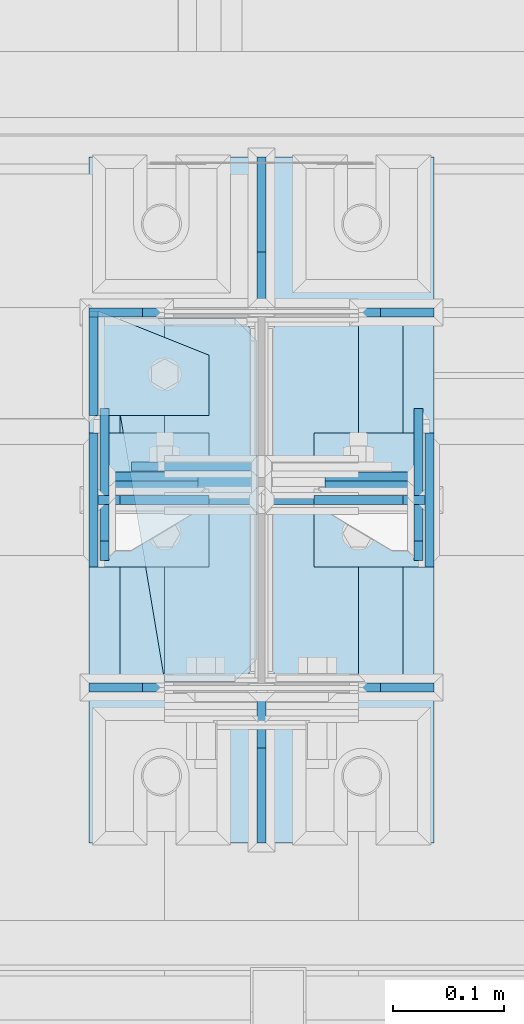
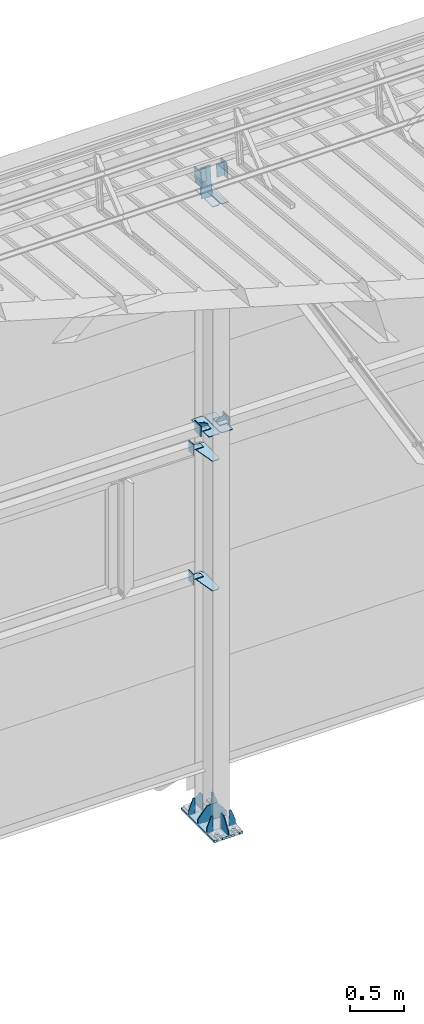
# One storey, part 160 of 709: 30 plates, 4 openings, 7 elements without a shape of their own.
"""IFC4 building model written with IfcOpenShell, lengths in millimetres."""

from ifc_helpers import new_model, si_unit, direction, frame, origin_with_axes, place, context, subcontext, project, spatial, line, arc, indexed_curve, outline, extrude, material, element, aggregate, save


model = new_model("IFC4")

# Units and contexts
model_context = context("Model", 3, precision=0.2, world=origin_with_axes(), true_north=direction((0.0, 1.0)))
body_context = subcontext(model_context, "Body", "Model", "MODEL_VIEW")
ifc_project = project(units=[si_unit("LENGTHUNIT", "METRE", prefix="MILLI"), si_unit("AREAUNIT", "SQUARE_METRE"), si_unit("VOLUMEUNIT", "CUBIC_METRE"), si_unit("MASSUNIT", "GRAM", prefix="KILO"), si_unit("TIMEUNIT", "SECOND"), si_unit("PLANEANGLEUNIT", "RADIAN"), si_unit("SOLIDANGLEUNIT", "STERADIAN"), si_unit("THERMODYNAMICTEMPERATUREUNIT", "DEGREE_CELSIUS"), si_unit("LUMINOUSINTENSITYUNIT", "LUMEN")], contexts=[model_context])

# Site, building, storey
site_placement = place(None, origin_with_axes())
site = spatial("IfcSite", under=ifc_project, at=site_placement, CompositionType="ELEMENT")
building_placement = place(site_placement, origin_with_axes())
building = spatial("IfcBuilding", under=site, at=building_placement, Name="Undefined", CompositionType="ELEMENT")
storey_placement = place(building_placement, origin_with_axes())
storey = spatial("IfcBuildingStorey", under=building, at=storey_placement, Name="Undefined", CompositionType="ELEMENT", Elevation=0.0)

# Assembly, plates, voiding features
assembly_1_placement = place(storey_placement, frame((34000.0, 21827.0, -200.0), z_axis=(-1.0, 0.0, 0.0), x_axis=(0.0, 0.0, 1.0)))
assembly_1 = element("IfcElementAssembly", 1, at=assembly_1_placement, inside=storey)
ifc_material = material(Name="C355-6", Category="STEEL")
plate_1_placement = place(assembly_1_placement, frame((12.5, -308.0, 155.0), z_axis=(1.0, 0.0, 0.0), x_axis=(0.0, 0.0, -1.0)))
plate_1 = element("IfcPlate", 2, at=plate_1_placement, material=ifc_material, ObjectType="416", context=body_context, shape_type="SolidModel", body=[
    extrude(outline(indexed_curve([(0.0, 0.0), (310.0, 0.0), (310.0, 616.0), (0.0, 616.0)], segments=[line(1, 2, 3, 4, 1)])), frame((0.0, 0.0, 12.5), z_axis=(0.0, 0.0, 1.0), x_axis=(1.0, 0.0, 0.0)), (0.0, 0.0, -1.0), 25.0),
])
voiding_feature_1_placement = place(plate_1_placement, frame((40.0, 616.0, 0.0), z_axis=(0.0, 0.0, -1.0), x_axis=(1.0, 0.0, 0.0)))
element("IfcVoidingFeature", 3, at=voiding_feature_1_placement, cuts=plate_1, PredefinedType="HOLE", context=body_context, shape_type="SolidModel", body=[
    extrude(outline(indexed_curve([(0.0, 0.0), (50.0, 0.0), (50.0, 60.0), (42.67767, 77.67767), (25.0, 85.0), (25.0, 85.0), (7.32233, 77.67767), (0.0, 60.0)], segments=[line(1, 2, 3), arc(3, 4, 5), line(5, 6), arc(6, 7, 8), line(8, 1)])), frame((0.0, 0.0, 12.5), z_axis=(0.0, 0.0, 1.0), x_axis=(1.0, 0.0, 0.0)), (0.0, 0.0, -1.0), 25.0),
])
voiding_feature_2_placement = place(plate_1_placement, frame((40.0, 0.0, 0.0), z_axis=(0.0, 0.0, 1.0), x_axis=(1.0, 0.0, 0.0)))
element("IfcVoidingFeature", 4, at=voiding_feature_2_placement, cuts=plate_1, PredefinedType="HOLE", context=body_context, shape_type="SolidModel", body=[
    extrude(outline(indexed_curve([(0.0, 0.0), (50.0, 0.0), (50.0, 60.0), (42.67767, 77.67767), (25.0, 85.0), (25.0, 85.0), (7.32233, 77.67767), (0.0, 60.0)], segments=[line(1, 2, 3), arc(3, 4, 5), line(5, 6), arc(6, 7, 8), line(8, 1)])), frame((0.0, 0.0, 12.5), z_axis=(0.0, 0.0, 1.0), x_axis=(1.0, 0.0, 0.0)), (0.0, 0.0, -1.0), 25.0),
])
voiding_feature_3_placement = place(plate_1_placement, frame((270.0, 616.0, 0.0), z_axis=(0.0, 0.0, 1.0), x_axis=(-1.0, 0.0, 0.0)))
element("IfcVoidingFeature", 5, at=voiding_feature_3_placement, cuts=plate_1, PredefinedType="HOLE", context=body_context, shape_type="SolidModel", body=[
    extrude(outline(indexed_curve([(0.0, 0.0), (50.0, 0.0), (50.0, 60.0), (42.67767, 77.67767), (25.0, 85.0), (25.0, 85.0), (7.32233, 77.67767), (0.0, 60.0)], segments=[line(1, 2, 3), arc(3, 4, 5), line(5, 6), arc(6, 7, 8), line(8, 1)])), frame((0.0, 0.0, 12.5), z_axis=(0.0, 0.0, 1.0), x_axis=(1.0, 0.0, 0.0)), (0.0, 0.0, -1.0), 25.0),
])
voiding_feature_4_placement = place(plate_1_placement, frame((270.0, 0.0, 0.0), z_axis=(0.0, 0.0, -1.0), x_axis=(-1.0, 0.0, 0.0)))
element("IfcVoidingFeature", 6, at=voiding_feature_4_placement, cuts=plate_1, PredefinedType="HOLE", context=body_context, shape_type="SolidModel", body=[
    extrude(outline(indexed_curve([(0.0, 0.0), (50.0, 0.0), (50.0, 60.0), (42.67767, 77.67767), (25.0, 85.0), (25.0, 85.0), (7.32233, 77.67767), (0.0, 60.0)], segments=[line(1, 2, 3), arc(3, 4, 5), line(5, 6), arc(6, 7, 8), line(8, 1)])), frame((0.0, 0.0, 12.5), z_axis=(0.0, 0.0, 1.0), x_axis=(1.0, 0.0, 0.0)), (0.0, 0.0, -1.0), 25.0),
])
plate_2_placement = place(assembly_1_placement, frame((25.0, 0.0, -3.0), z_axis=(0.0, -1.0, 0.0), x_axis=(0.0, 0.0, -1.0)))
plate_2 = element("IfcPlate", 7, at=plate_2_placement, material=ifc_material, ObjectType="417", context=body_context, shape_type="SolidModel", body=[
    extrude(outline(indexed_curve([(0.0, 0.0), (152.0, 0.0), (152.0, 50.0), (50.0, 175.0), (0.0, 175.0)], segments=[line(1, 2, 3, 4, 5, 1)])), frame((0.0, 0.0, 4.0), z_axis=(0.0, 0.0, 1.0), x_axis=(1.0, 0.0, 0.0)), (0.0, 0.0, -1.0), 8.0),
])
plate_3_placement = place(assembly_1_placement, frame((25.0, -168.5, 87.0), z_axis=(0.0, 1.0, 0.0), x_axis=(0.0, 0.0, 1.0)))
plate_3 = element("IfcPlate", 8, at=plate_3_placement, material=ifc_material, ObjectType="419", context=body_context, shape_type="SolidModel", body=[
    extrude(outline(indexed_curve([(0.0, 0.0), (68.0, 0.0), (68.0, 50.0), (20.0, 175.0), (0.0, 175.0)], segments=[line(1, 2, 3, 4, 5, 1)])), frame((0.0, 0.0, 4.0), z_axis=(0.0, 0.0, 1.0), x_axis=(1.0, 0.0, 0.0)), (0.0, 0.0, -1.0), 8.0),
])
plate_4_placement = place(assembly_1_placement, frame((25.0, 0.0, 3.0), z_axis=(0.0, 1.0, 0.0), x_axis=(0.0, 0.0, 1.0)))
plate_4 = element("IfcPlate", 9, at=plate_4_placement, material=ifc_material, ObjectType="417", context=body_context, shape_type="SolidModel", body=[
    extrude(outline(indexed_curve([(0.0, 0.0), (152.0, 0.0), (152.0, 50.0), (50.0, 175.0), (0.0, 175.0)], segments=[line(1, 2, 3, 4, 5, 1)])), frame((0.0, 0.0, 4.0), z_axis=(0.0, 0.0, 1.0), x_axis=(1.0, 0.0, 0.0)), (0.0, 0.0, -1.0), 8.0),
])
plate_5_placement = place(assembly_1_placement, frame((25.0, 173.0, 0.0), z_axis=(0.0, 0.0, -1.0), x_axis=(0.0, 1.0, 0.0)))
plate_5 = element("IfcPlate", 10, at=plate_5_placement, material=ifc_material, ObjectType="418", context=body_context, shape_type="SolidModel", body=[
    extrude(outline(indexed_curve([(0.0, 0.0), (135.0, 0.0), (135.0, 50.0), (50.0, 175.0), (0.0, 175.0)], segments=[line(1, 2, 3, 4, 5, 1)])), frame((0.0, 0.0, 4.0), z_axis=(0.0, 0.0, 1.0), x_axis=(1.0, 0.0, 0.0)), (0.0, 0.0, -1.0), 8.0),
])
plate_6_placement = place(assembly_1_placement, frame((25.0, -173.0, 0.0), z_axis=(0.0, 0.0, 1.0), x_axis=(0.0, -1.0, 0.0)))
plate_6 = element("IfcPlate", 11, at=plate_6_placement, material=ifc_material, ObjectType="418", context=body_context, shape_type="SolidModel", body=[
    extrude(outline(indexed_curve([(0.0, 0.0), (135.0, 0.0), (135.0, 50.0), (50.0, 175.0), (0.0, 175.0)], segments=[line(1, 2, 3, 4, 5, 1)])), frame((0.0, 0.0, 4.0), z_axis=(0.0, 0.0, 1.0), x_axis=(1.0, 0.0, 0.0)), (0.0, 0.0, -1.0), 8.0),
])
plate_7_placement = place(assembly_1_placement, frame((25.0, -168.5, -87.0), z_axis=(0.0, -1.0, 0.0), x_axis=(0.0, 0.0, -1.0)))
plate_7 = element("IfcPlate", 12, at=plate_7_placement, material=ifc_material, ObjectType="419", context=body_context, shape_type="SolidModel", body=[
    extrude(outline(indexed_curve([(0.0, 0.0), (68.0, 0.0), (68.0, 50.0), (20.0, 175.0), (0.0, 175.0)], segments=[line(1, 2, 3, 4, 5, 1)])), frame((0.0, 0.0, 4.0), z_axis=(0.0, 0.0, 1.0), x_axis=(1.0, 0.0, 0.0)), (0.0, 0.0, -1.0), 8.0),
])
plate_8_placement = place(assembly_1_placement, frame((25.0, 168.5, -87.0), z_axis=(0.0, -1.0, 0.0), x_axis=(0.0, 0.0, -1.0)))
plate_8 = element("IfcPlate", 13, at=plate_8_placement, material=ifc_material, ObjectType="419", context=body_context, shape_type="SolidModel", body=[
    extrude(outline(indexed_curve([(0.0, 0.0), (68.0, 0.0), (68.0, 50.0), (20.0, 175.0), (0.0, 175.0)], segments=[line(1, 2, 3, 4, 5, 1)])), frame((0.0, 0.0, 4.0), z_axis=(0.0, 0.0, 1.0), x_axis=(1.0, 0.0, 0.0)), (0.0, 0.0, -1.0), 8.0),
])
plate_9_placement = place(assembly_1_placement, frame((25.0, 168.5, 87.0), z_axis=(0.0, 1.0, 0.0), x_axis=(0.0, 0.0, 1.0)))
plate_9 = element("IfcPlate", 14, at=plate_9_placement, material=ifc_material, ObjectType="419", context=body_context, shape_type="SolidModel", body=[
    extrude(outline(indexed_curve([(0.0, 0.0), (68.0, 0.0), (68.0, 50.0), (20.0, 175.0), (0.0, 175.0)], segments=[line(1, 2, 3, 4, 5, 1)])), frame((0.0, 0.0, 4.0), z_axis=(0.0, 0.0, 1.0), x_axis=(1.0, 0.0, 0.0)), (0.0, 0.0, -1.0), 8.0),
])
plate_10_placement = place(assembly_1_placement, frame((7097.93718, -163.0, -87.0), z_axis=(-1.0, 0.0, 0.0), x_axis=(0.0, 0.0, 1.0)))
plate_10 = element("IfcPlate", 15, at=plate_10_placement, material=ifc_material, ObjectType="461", context=body_context, shape_type="SolidModel", body=[
    extrude(outline(indexed_curve([(0.0, 0.0), (68.0, 0.0), (83.0, 15.0), (83.0, 311.0), (68.0, 326.0), (0.0, 326.0)], segments=[line(1, 2, 3, 4, 5, 6, 1)])), frame((0.0, 0.0, 4.0), z_axis=(0.0, 0.0, 1.0), x_axis=(1.0, 0.0, 0.0)), (0.0, 0.0, -1.0), 8.0),
])
plate_11_placement = place(assembly_1_placement, frame((7097.93718, 163.0, 87.0), z_axis=(-1.0, 0.0, 0.0), x_axis=(0.0, 0.0, -1.0)))
plate_11 = element("IfcPlate", 16, at=plate_11_placement, material=ifc_material, ObjectType="461", context=body_context, shape_type="SolidModel", body=[
    extrude(outline(indexed_curve([(0.0, 0.0), (68.0, 0.0), (83.0, 15.0), (83.0, 311.0), (68.0, 326.0), (0.0, 326.0)], segments=[line(1, 2, 3, 4, 5, 6, 1)])), frame((0.0, 0.0, 4.0), z_axis=(0.0, 0.0, 1.0), x_axis=(1.0, 0.0, 0.0)), (0.0, 0.0, -1.0), 8.0),
])
plate_12_placement = place(assembly_1_placement, frame((4502.0, -163.0, -127.0), z_axis=(-1.0, 0.0, 0.0), x_axis=(0.0, 0.0, 1.0)))
plate_12 = element("IfcPlate", 17, at=plate_12_placement, material=ifc_material, ObjectType="547", context=body_context, shape_type="SolidModel", body=[
    extrude(outline(indexed_curve([(0.0, 0.0), (108.0, 0.0), (123.0, 15.0), (123.0, 311.0), (108.0, 326.0), (0.0, 326.0)], segments=[line(1, 2, 3, 4, 5, 6, 1)])), frame((0.0, 0.0, 4.0), z_axis=(0.0, 0.0, 1.0), x_axis=(1.0, 0.0, 0.0)), (0.0, 0.0, -1.0), 8.0),
])
plate_13_placement = place(assembly_1_placement, frame((2742.0, 163.0, 4.0), z_axis=(1.0, 0.0, 0.0), x_axis=(0.0, 0.0, 1.0)))
plate_13 = element("IfcPlate", 18, at=plate_13_placement, material=ifc_material, ObjectType="543", context=body_context, shape_type="SolidModel", body=[
    extrude(outline(indexed_curve([(0.0, 20.0), (20.0, 0.0), (123.0, 0.0), (123.0, 86.0), (83.0, 326.0), (20.0, 326.0), (0.0, 306.0)], segments=[line(1, 2, 3, 4, 5, 6, 7, 1)])), frame((0.0, 0.0, 4.0), z_axis=(0.0, 0.0, 1.0), x_axis=(1.0, 0.0, 0.0)), (0.0, 0.0, -1.0), 8.0),
])
plate_14_placement = place(assembly_1_placement, frame((4212.0, 163.0, 4.0), z_axis=(1.0, 0.0, 0.0), x_axis=(0.0, 0.0, 1.0)))
plate_14 = element("IfcPlate", 19, at=plate_14_placement, material=ifc_material, ObjectType="543", context=body_context, shape_type="SolidModel", body=[
    extrude(outline(indexed_curve([(0.0, 20.0), (20.0, 0.0), (123.0, 0.0), (123.0, 86.0), (83.0, 326.0), (20.0, 326.0), (0.0, 306.0)], segments=[line(1, 2, 3, 4, 5, 6, 7, 1)])), frame((0.0, 0.0, 4.0), z_axis=(0.0, 0.0, 1.0), x_axis=(1.0, 0.0, 0.0)), (0.0, 0.0, -1.0), 8.0),
])
plate_15_placement = place(assembly_1_placement, frame((4502.0, 163.0, 127.0), z_axis=(-1.0, 0.0, 0.0), x_axis=(0.0, 0.0, -1.0)))
plate_15 = element("IfcPlate", 20, at=plate_15_placement, material=ifc_material, ObjectType="547", context=body_context, shape_type="SolidModel", body=[
    extrude(outline(indexed_curve([(0.0, 0.0), (108.0, 0.0), (123.0, 15.0), (123.0, 311.0), (108.0, 326.0), (0.0, 326.0)], segments=[line(1, 2, 3, 4, 5, 6, 1)])), frame((0.0, 0.0, 4.0), z_axis=(0.0, 0.0, 1.0), x_axis=(1.0, 0.0, 0.0)), (0.0, 0.0, -1.0), 8.0),
])
plate_16_placement = place(assembly_1_placement, frame((7434.21546, 30.02526, 3.0), z_axis=(0.099503719, -0.9950371902, 0.0), x_axis=(0.0, 0.0, 1.0)))
plate_16 = element("IfcPlate", 21, at=plate_16_placement, material=ifc_material, ObjectType="595", context=body_context, shape_type="SolidModel", body=[
    extrude(outline(indexed_curve([(0.0, 0.0), (114.0, 0.0), (114.0, 332.53554), (0.0, 332.53554)], segments=[line(1, 2, 3, 4, 1)])), frame((0.0, 0.0, 4.0), z_axis=(0.0, 0.0, 1.0), x_axis=(1.0, 0.0, 0.0)), (0.0, 0.0, -1.0), 8.0),
])
aggregate(assembly_1, [plate_1, plate_2, plate_3, plate_4, plate_5, plate_6, plate_7, plate_8, plate_9, plate_10, plate_11, plate_12, plate_13, plate_14, plate_15, plate_16])

# Assembly, plates
assembly_2_placement = place(storey_placement, frame((40000.0, 21827.0, 4310.0), z_axis=(0.0, 0.0, -1.0), x_axis=(-1.0, 0.0, 0.0)))
assembly_2 = element("IfcElementAssembly", 22, at=assembly_2_placement, inside=storey)
plate_17_placement = place(assembly_2_placement, frame((5849.0, -60.0, 60.0), z_axis=(1.0, 0.0, 0.0), x_axis=(0.0, 0.0, -1.0)))
plate_17 = element("IfcPlate", 23, at=plate_17_placement, material=ifc_material, ObjectType="506", context=body_context, shape_type="SolidModel", body=[
    extrude(outline(indexed_curve([(0.0, 0.0), (120.0, 0.0), (120.0, 120.0), (0.0, 120.0)], segments=[line(1, 2, 3, 4, 1)])), frame((0.0, 0.0, 4.0), z_axis=(0.0, 0.0, 1.0), x_axis=(1.0, 0.0, 0.0)), (0.0, 0.0, -1.0), 8.0),
])
plate_18_placement = place(assembly_2_placement, frame((5953.0, -60.0, 0.0), z_axis=(0.0, 0.0, 1.0), x_axis=(0.0, 1.0, 0.0)))
plate_18 = element("IfcPlate", 24, at=plate_18_placement, material=ifc_material, ObjectType="507", context=body_context, shape_type="SolidModel", body=[
    extrude(outline(indexed_curve([(0.0, 0.0), (120.0, 0.0), (120.0, 100.0), (0.0, 100.0)], segments=[line(1, 2, 3, 4, 1)])), frame((0.0, 0.0, 4.0), z_axis=(0.0, 0.0, 1.0), x_axis=(1.0, 0.0, 0.0)), (0.0, 0.0, -1.0), 8.0),
])
plate_19_placement = place(assembly_2_placement, frame((5953.0, 0.0, -60.0), z_axis=(0.0, -1.0, 0.0), x_axis=(0.0, 0.0, 1.0)))
plate_19 = element("IfcPlate", 25, at=plate_19_placement, material=ifc_material, ObjectType="508", context=body_context, shape_type="SolidModel", body=[
    extrude(outline(indexed_curve([(0.0, 80.0), (36.0, 0.0), (56.0, 0.0), (56.0, 90.0), (46.0, 100.0), (0.0, 100.0)], segments=[line(1, 2, 3, 4, 5, 6, 1)])), frame((0.0, 0.0, 4.0), z_axis=(0.0, 0.0, 1.0), x_axis=(1.0, 0.0, 0.0)), (0.0, 0.0, -1.0), 8.0),
])
aggregate(assembly_2, [plate_17, plate_18, plate_19])

assembly_3_placement = place(storey_placement, frame((34000.0, 21950.0, 2550.0), z_axis=(0.0, 0.0, -1.0), x_axis=(-1.0, 0.0, 0.0)))
assembly_3 = element("IfcElementAssembly", 26, at=assembly_3_placement, inside=storey)
plate_20_placement = place(assembly_3_placement, frame((151.0, 47.0, -60.0), z_axis=(-1.0, 0.0, 0.0), x_axis=(0.0, -1.0, 0.0)))
plate_20 = element("IfcPlate", 27, at=plate_20_placement, material=ifc_material, ObjectType="501", context=body_context, shape_type="SolidModel", body=[
    extrude(outline(indexed_curve([(0.0, 0.0), (94.0, 0.0), (94.0, 120.0), (0.0, 120.0)], segments=[line(1, 2, 3, 4, 1)])), frame((0.0, 0.0, 4.0), z_axis=(0.0, 0.0, 1.0), x_axis=(1.0, 0.0, 0.0)), (0.0, 0.0, -1.0), 8.0),
])
plate_21_placement = place(assembly_3_placement, frame((47.0, 47.0, 0.0), z_axis=(0.0, 0.0, 1.0), x_axis=(0.0, -1.0, 0.0)))
plate_21 = element("IfcPlate", 28, at=plate_21_placement, material=ifc_material, ObjectType="502", context=body_context, shape_type="SolidModel", body=[
    extrude(outline(indexed_curve([(0.0, 100.0), (40.0, 0.0), (94.0, 0.0), (94.0, 100.0), (0.0, 100.0)], segments=[line(1, 2, 3, 4, 5, 1)])), frame((0.0, 0.0, 4.0), z_axis=(0.0, 0.0, 1.0), x_axis=(1.0, 0.0, 0.0)), (0.0, 0.0, -1.0), 8.0),
])
aggregate(assembly_3, [plate_20, plate_21])

assembly_4_placement = place(storey_placement, frame((34000.0, 21950.0, 4020.0), z_axis=(0.0, 0.0, -1.0), x_axis=(-1.0, 0.0, 0.0)))
assembly_4 = element("IfcElementAssembly", 29, at=assembly_4_placement, inside=storey)
plate_22_placement = place(assembly_4_placement, frame((151.0, 47.0, -60.0), z_axis=(-1.0, 0.0, 0.0), x_axis=(0.0, -1.0, 0.0)))
plate_22 = element("IfcPlate", 30, at=plate_22_placement, material=ifc_material, ObjectType="501", context=body_context, shape_type="SolidModel", body=[
    extrude(outline(indexed_curve([(0.0, 0.0), (94.0, 0.0), (94.0, 120.0), (0.0, 120.0)], segments=[line(1, 2, 3, 4, 1)])), frame((0.0, 0.0, 4.0), z_axis=(0.0, 0.0, 1.0), x_axis=(1.0, 0.0, 0.0)), (0.0, 0.0, -1.0), 8.0),
])
plate_23_placement = place(assembly_4_placement, frame((47.0, 47.0, 0.0), z_axis=(0.0, 0.0, 1.0), x_axis=(0.0, -1.0, 0.0)))
plate_23 = element("IfcPlate", 31, at=plate_23_placement, material=ifc_material, ObjectType="502", context=body_context, shape_type="SolidModel", body=[
    extrude(outline(indexed_curve([(0.0, 100.0), (40.0, 0.0), (94.0, 0.0), (94.0, 100.0), (0.0, 100.0)], segments=[line(1, 2, 3, 4, 5, 1)])), frame((0.0, 0.0, 4.0), z_axis=(0.0, 0.0, 1.0), x_axis=(1.0, 0.0, 0.0)), (0.0, 0.0, -1.0), 8.0),
])
aggregate(assembly_4, [plate_22, plate_23])

assembly_5_placement = place(storey_placement, frame((34000.0, 21827.0, 4310.0), z_axis=(0.0, 0.0, -1.0), x_axis=(-1.0, 0.0, 0.0)))
assembly_5 = element("IfcElementAssembly", 32, at=assembly_5_placement, inside=storey)
plate_24_placement = place(assembly_5_placement, frame((47.0, 0.0, -60.0), z_axis=(0.0, 1.0, 0.0), x_axis=(0.0, 0.0, 1.0)))
plate_24 = element("IfcPlate", 33, at=plate_24_placement, material=ifc_material, ObjectType="508", context=body_context, shape_type="SolidModel", body=[
    extrude(outline(indexed_curve([(0.0, 80.0), (36.0, 0.0), (56.0, 0.0), (56.0, 90.0), (46.0, 100.0), (0.0, 100.0)], segments=[line(1, 2, 3, 4, 5, 6, 1)])), frame((0.0, 0.0, 4.0), z_axis=(0.0, 0.0, 1.0), x_axis=(1.0, 0.0, 0.0)), (0.0, 0.0, -1.0), 8.0),
])
plate_25_placement = place(assembly_5_placement, frame((47.0, 60.0, 0.0), z_axis=(0.0, 0.0, 1.0), x_axis=(0.0, -1.0, 0.0)))
plate_25 = element("IfcPlate", 34, at=plate_25_placement, material=ifc_material, ObjectType="507", context=body_context, shape_type="SolidModel", body=[
    extrude(outline(indexed_curve([(0.0, 0.0), (120.0, 0.0), (120.0, 100.0), (0.0, 100.0)], segments=[line(1, 2, 3, 4, 1)])), frame((0.0, 0.0, 4.0), z_axis=(0.0, 0.0, 1.0), x_axis=(1.0, 0.0, 0.0)), (0.0, 0.0, -1.0), 8.0),
])
plate_26_placement = place(assembly_5_placement, frame((151.0, 60.0, 60.0), z_axis=(-1.0, 0.0, 0.0), x_axis=(0.0, 0.0, -1.0)))
plate_26 = element("IfcPlate", 35, at=plate_26_placement, material=ifc_material, ObjectType="506", context=body_context, shape_type="SolidModel", body=[
    extrude(outline(indexed_curve([(0.0, 0.0), (120.0, 0.0), (120.0, 120.0), (0.0, 120.0)], segments=[line(1, 2, 3, 4, 1)])), frame((0.0, 0.0, 4.0), z_axis=(0.0, 0.0, 1.0), x_axis=(1.0, 0.0, 0.0)), (0.0, 0.0, -1.0), 8.0),
])
aggregate(assembly_5, [plate_24, plate_25, plate_26])

assembly_6_placement = place(storey_placement, frame((34000.0, 21841.04467, 7154.40952), z_axis=(0.0, -0.9950371902, 0.099503719), x_axis=(-1.0, 0.0, 0.0)))
assembly_6 = element("IfcElementAssembly", 36, at=assembly_6_placement, inside=storey)
plate_27_placement = place(assembly_6_placement, frame((141.0, -87.0, -60.0), z_axis=(-1.0, 0.0, 0.0), x_axis=(0.0, 0.0, 1.0)))
plate_27 = element("IfcPlate", 37, at=plate_27_placement, material=ifc_material, ObjectType="596", context=body_context, shape_type="SolidModel", body=[
    extrude(outline(indexed_curve([(0.0, 0.0), (120.0, 0.0), (120.0, 174.0), (0.0, 174.0)], segments=[line(1, 2, 3, 4, 1)])), frame((0.0, 0.0, 4.0), z_axis=(0.0, 0.0, 1.0), x_axis=(1.0, 0.0, 0.0)), (0.0, 0.0, -1.0), 8.0),
])
plate_28_placement = place(assembly_6_placement, frame((57.0, -72.0, 0.0), z_axis=(0.0, 0.0, 1.0), x_axis=(1.0, 0.0, 0.0)))
plate_28 = element("IfcPlate", 38, at=plate_28_placement, material=ifc_material, ObjectType="597", context=body_context, shape_type="SolidModel", body=[
    extrude(outline(indexed_curve([(0.0, 0.0), (80.0, 0.0), (80.0, 144.0), (0.0, 144.0)], segments=[line(1, 2, 3, 4, 1)])), frame((0.0, 0.0, 4.0), z_axis=(0.0, 0.0, 1.0), x_axis=(1.0, 0.0, 0.0)), (0.0, 0.0, -1.0), 8.0),
])
aggregate(assembly_6, [plate_27, plate_28])

assembly_7_placement = place(storey_placement, frame((40000.0, 21841.04467, 7154.40952), z_axis=(0.0, -0.9950371902, 0.099503719), x_axis=(-1.0, 0.0, 0.0)))
assembly_7 = element("IfcElementAssembly", 39, at=assembly_7_placement, inside=storey)
plate_29_placement = place(assembly_7_placement, frame((5943.0, 72.0, 0.0), z_axis=(0.0, 0.0, 1.0), x_axis=(-1.0, 0.0, 0.0)))
plate_29 = element("IfcPlate", 40, at=plate_29_placement, material=ifc_material, ObjectType="597", context=body_context, shape_type="SolidModel", body=[
    extrude(outline(indexed_curve([(0.0, 0.0), (80.0, 0.0), (80.0, 144.0), (0.0, 144.0)], segments=[line(1, 2, 3, 4, 1)])), frame((0.0, 0.0, 4.0), z_axis=(0.0, 0.0, 1.0), x_axis=(1.0, 0.0, 0.0)), (0.0, 0.0, -1.0), 8.0),
])
plate_30_placement = place(assembly_7_placement, frame((5859.0, -87.0, 60.0), z_axis=(1.0, 0.0, 0.0), x_axis=(0.0, 0.0, -1.0)))
plate_30 = element("IfcPlate", 41, at=plate_30_placement, material=ifc_material, ObjectType="596", context=body_context, shape_type="SolidModel", body=[
    extrude(outline(indexed_curve([(0.0, 0.0), (120.0, 0.0), (120.0, 174.0), (0.0, 174.0)], segments=[line(1, 2, 3, 4, 1)])), frame((0.0, 0.0, 4.0), z_axis=(0.0, 0.0, 1.0), x_axis=(1.0, 0.0, 0.0)), (0.0, 0.0, -1.0), 8.0),
])
aggregate(assembly_7, [plate_29, plate_30])

save(model, "model.ifc")
